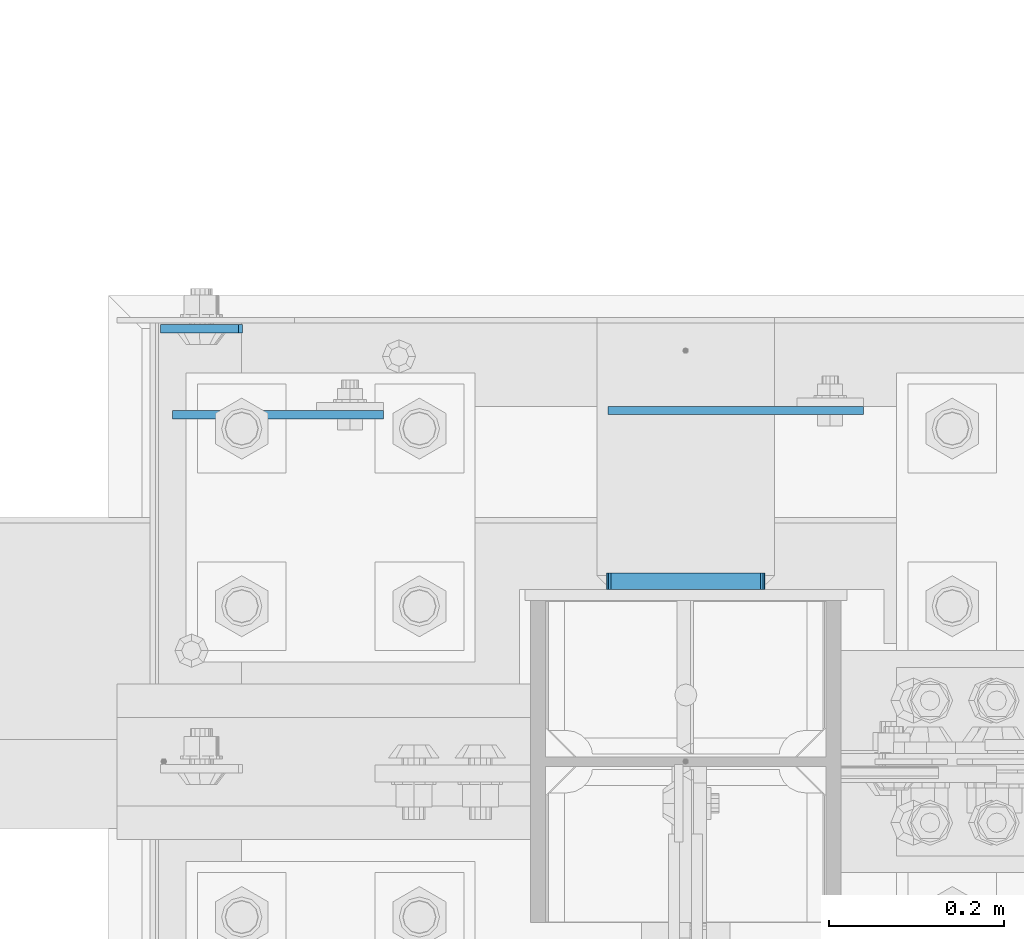
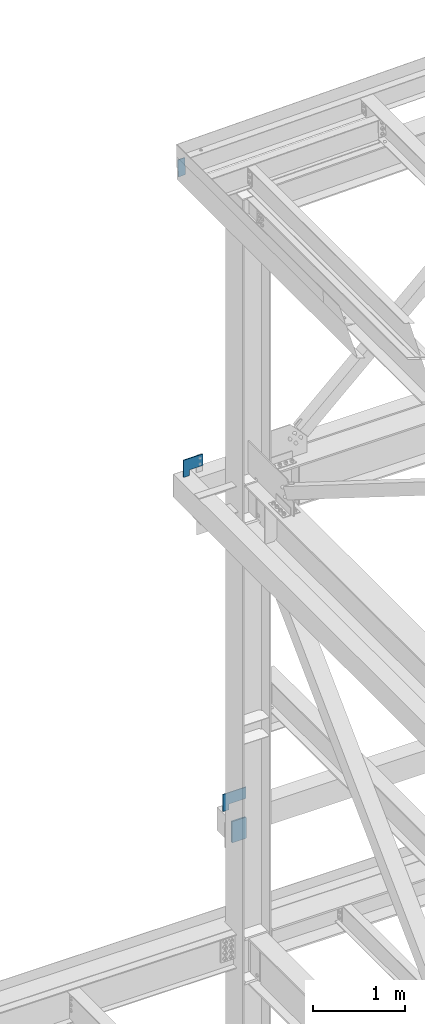
# One storey, part 3540 of 3843: 4 plates, 3 elements without a shape of their own.
"""IFC2X3 building model written with IfcOpenShell, lengths in millimetres."""

from ifc_helpers import new_model, si_unit, frame, origin_with_axes, place, context, subcontext, project, spatial, faceted_brep, material, type_object, element, aggregate, save


model = new_model("IFC2X3")

# Units and contexts
model_context = context("Model", 3, precision=1e-05, world=origin_with_axes())
body_context = subcontext(model_context, "Body", "Model", "MODEL_VIEW")
ifc_project = project(units=[si_unit("LENGTHUNIT", "METRE", prefix="MILLI"), si_unit("AREAUNIT", "SQUARE_METRE"), si_unit("VOLUMEUNIT", "CUBIC_METRE"), si_unit("MASSUNIT", "GRAM", prefix="KILO"), si_unit("TIMEUNIT", "SECOND"), si_unit("PLANEANGLEUNIT", "RADIAN"), si_unit("SOLIDANGLEUNIT", "STERADIAN"), si_unit("THERMODYNAMICTEMPERATUREUNIT", "DEGREE_CELSIUS"), si_unit("LUMINOUSINTENSITYUNIT", "LUMEN")], contexts=[model_context])

# Site, building, storey
site_placement = place(None, origin_with_axes())
site = spatial("IfcSite", under=ifc_project, at=site_placement, CompositionType="ELEMENT")
building_placement = place(site_placement, origin_with_axes())
building = spatial("IfcBuilding", under=site, at=building_placement, Name="Undefined", CompositionType="ELEMENT")
storey_placement = place(building_placement, origin_with_axes())
storey = spatial("IfcBuildingStorey", under=building, at=storey_placement, Name="Undefined", CompositionType="ELEMENT", Elevation=0.0)

# Assembly, plate
assembly_1_placement = place(storey_placement, origin_with_axes())
assembly_1 = element("IfcElementAssembly", 1, at=assembly_1_placement, inside=storey, Name="CHANNEL", AssemblyPlace="NOTDEFINED", PredefinedType="RIGID_FRAME")
ifc_material = material(Name="STEEL/A572-50")
plate_type_1 = type_object("IfcPlateType", PredefinedType="NOTDEFINED")
plate_1_placement = place(assembly_1_placement, frame((76411.9416190503, 105054.400000026, 46534.2884078135), z_axis=(0.999776270257024, 0.0, 0.0211520550054619), x_axis=(0.0211520550054438, 0.0, -0.999776270257025)))
plate_1 = element("IfcPlate", 2, at=plate_1_placement, type_object=plate_type_1, material=ifc_material, Name="PLATE", context=body_context, shape_type="Brep", body=[
    faceted_brep([(0.0, -4.76249999999709, 0.0), (0.0, -4.76249999999709, 88.9000015258789), (0.0, 4.76249999999709, 88.9000015258789), (0.0, 4.76249999999709, 0.0), (228.600006102781, -4.7625000004191, 88.9000015257589), (228.600006102781, 4.76249999954598, 88.9000015257443), (228.600006103079, -4.7625000004482, 7.27595761418343e-12), (228.600006103079, 4.76249999954598, -7.27595761418343e-12)], [[[0, 1, 2, 3]], [[1, 4, 5, 2]], [[4, 6, 7, 5]], [[6, 0, 3, 7]], [[5, 7, 3, 2]], [[6, 4, 1, 0]]]),
])
aggregate(assembly_1, [plate_1])

assembly_2_placement = place(storey_placement, origin_with_axes())
assembly_2 = element("IfcElementAssembly", 3, at=assembly_2_placement, inside=storey, Name="COLUMN", AssemblyPlace="NOTDEFINED", PredefinedType="RIGID_FRAME")
plate_type_2 = type_object("IfcPlateType", PredefinedType="NOTDEFINED")
plate_2_placement = place(assembly_2_placement, frame((76923.9, 104960.7375, 37744.4), z_axis=(0.0, 0.0, 1.0), x_axis=(1.0, 0.0, 0.0)))
plate_2 = element("IfcPlate", 4, at=plate_2_placement, type_object=plate_type_2, material=ifc_material, Name="PLATE", context=body_context, shape_type="Brep", body=[
    faceted_brep([(0.0, -4.76249999999709, 0.0), (0.0, -4.76249999999709, 228.599999999999), (0.0, 4.76249999999709, 228.599999999999), (0.0, 4.76249999999709, 0.0), (292.100006103516, -4.76249999999709, 228.600006103516), (292.100006103516, 4.76249999999709, 228.600006103516), (292.100006103516, -4.76249999999709, 76.1999969482422), (292.100006103516, 4.76249999999709, 76.1999969482422), (76.1999893188477, -4.76249999999709, 76.1999969482422), (76.1999893188477, 4.76249999999709, 76.1999969482422), (76.2000000012922, -4.76250000000073, 7.27595761418343e-11), (76.2000000012922, 4.76250000000073, 7.27595761418343e-11)], [[[0, 1, 2, 3]], [[1, 4, 5, 2]], [[4, 6, 7, 5]], [[6, 8, 9, 7]], [[8, 10, 11, 9]], [[10, 0, 3, 11]], [[5, 7, 9, 11, 3, 2]], [[10, 8, 6, 4, 1, 0]]]),
])

assembly_3_placement = place(storey_placement, origin_with_axes())
assembly_3 = element("IfcElementAssembly", 5, at=assembly_3_placement, inside=storey, Name="GIRT", AssemblyPlace="NOTDEFINED", PredefinedType="RIGID_FRAME")
plate_3_placement = place(assembly_3_placement, frame((76425.425, 104955.9745, 42367.2), z_axis=(0.0, 0.0, 1.0), x_axis=(1.0, 0.0, 0.0)))
plate_3 = element("IfcPlate", 6, at=plate_3_placement, type_object=plate_type_2, material=ifc_material, Name="PLATE", context=body_context, shape_type="Brep", body=[
    faceted_brep([(0.0, -4.76249999999709, 0.0), (0.0, -4.76249999999709, 228.599999999999), (0.0, 4.76249999999709, 228.599999999999), (0.0, 4.76249999999709, 0.0), (241.300018310547, -4.76249999999709, 228.600006103516), (241.300018310547, 4.76249999999709, 228.600006103516), (241.300018310547, -4.76249999999709, 76.1999969482422), (241.300018310547, 4.76249999999709, 76.1999969482422), (76.1999893188477, -4.76249999999709, 76.1999969482422), (76.1999893188477, 4.76249999999709, 76.1999969482422), (76.2000000012922, -4.76250000000073, 7.27595761418343e-11), (76.2000000012922, 4.76250000000073, 7.27595761418343e-11)], [[[0, 1, 2, 3]], [[1, 4, 5, 2]], [[4, 6, 7, 5]], [[6, 8, 9, 7]], [[8, 10, 11, 9]], [[10, 0, 3, 11]], [[5, 7, 9, 11, 3, 2]], [[10, 8, 6, 4, 1, 0]]]),
])
aggregate(assembly_3, [plate_3])

# Plate
plate_type_3 = type_object("IfcPlateType", PredefinedType="NOTDEFINED")
plate_4_placement = place(assembly_2_placement, frame((76922.3125, 104765.475, 37733.6551879883), z_axis=(1.0, 0.0, 0.0), x_axis=(0.0, 0.0, -1.0)))
plate_4 = element("IfcPlate", 7, at=plate_4_placement, type_object=plate_type_3, material=ifc_material, Name="PLATE", context=body_context, shape_type="Brep", body=[
    faceted_brep([(-8.22591685395256e-13, -9.52499999999854, 7.9375), (0.0, -9.52499999999418, 173.037499999991), (0.0, 9.52499999999418, 173.037499999991), (0.0, 9.52499999999418, 7.9375), (0.604206210693519, -9.52499999999418, 176.075049744395), (0.604206210693519, 9.52499999999418, 176.075049744395), (2.32483992433117, -9.52499999999418, 178.65016007566), (2.32483992433117, 9.52499999999418, 178.65016007566), (4.89995025560347, -9.52499999999418, 180.370793789305), (4.89995025560347, 9.52499999999418, 180.370793789305), (7.9375, -9.52499999999418, 180.974999999991), (7.9375, 9.52499999999418, 180.974999999991), (274.637499999997, -9.52499999999418, 180.974999999991), (274.637499999997, 9.52499999999418, 180.974999999991), (277.675049744394, -9.52499999999418, 180.370793789305), (277.675049744394, 9.52499999999418, 180.370793789305), (280.250160075666, -9.52499999999418, 178.65016007566), (280.250160075666, 9.52499999999418, 178.65016007566), (281.970793789304, -9.52499999999418, 176.075049744395), (281.970793789304, 9.52499999999418, 176.075049744395), (282.574999999997, -9.52499999999418, 173.037499999991), (282.574999999997, 9.52499999999418, 173.037499999991), (282.574999999997, -9.52499999999418, 7.9375), (282.574999999997, 9.52499999999418, 7.9375), (281.970793789304, -9.52499999999418, 4.8999502555962), (281.970793789304, 9.52499999999418, 4.8999502555962), (280.250160075666, -9.52499999999418, 2.32483992433117), (280.250160075666, 9.52499999999418, 2.32483992433117), (277.675049744394, -9.52499999999418, 0.604206210686243), (277.675049744394, 9.52499999999418, 0.604206210686243), (274.637499999997, -9.52499999999418, 0.0), (274.637499999997, 9.52499999999418, 0.0), (7.9375, -9.52499999999854, 0.0), (7.9375, 9.52499999999418, 0.0), (4.8999502555962, -9.52499999999418, 0.604206210693519), (4.8999502555962, 9.52499999999418, 0.604206210693519), (2.32483992433117, -9.52499999999418, 2.32483992433117), (2.32483992433117, 9.52499999999418, 2.32483992433117), (0.604206210686243, -9.52499999999418, 4.89995025560347), (0.604206210686243, 9.52499999999418, 4.89995025560347)], [[[0, 1, 2, 3]], [[1, 4, 5, 2]], [[4, 6, 7, 5]], [[6, 8, 9, 7]], [[8, 10, 11, 9]], [[10, 12, 13, 11]], [[12, 14, 15, 13]], [[14, 16, 17, 15]], [[16, 18, 19, 17]], [[18, 20, 21, 19]], [[20, 22, 23, 21]], [[22, 24, 25, 23]], [[24, 26, 27, 25]], [[26, 28, 29, 27]], [[28, 30, 31, 29]], [[30, 32, 33, 31]], [[32, 34, 35, 33]], [[34, 36, 37, 35]], [[36, 38, 39, 37]], [[38, 0, 3, 39]], [[5, 7, 9, 11, 13, 15, 17, 19, 21, 23, 25, 27, 29, 31, 33, 35, 37, 39, 3, 2]], [[38, 36, 34, 32, 30, 28, 26, 24, 22, 20, 18, 16, 14, 12, 10, 8, 6, 4, 1, 0]]]),
])

aggregate(assembly_2, [plate_4, plate_2])

save(model, "model.ifc")
